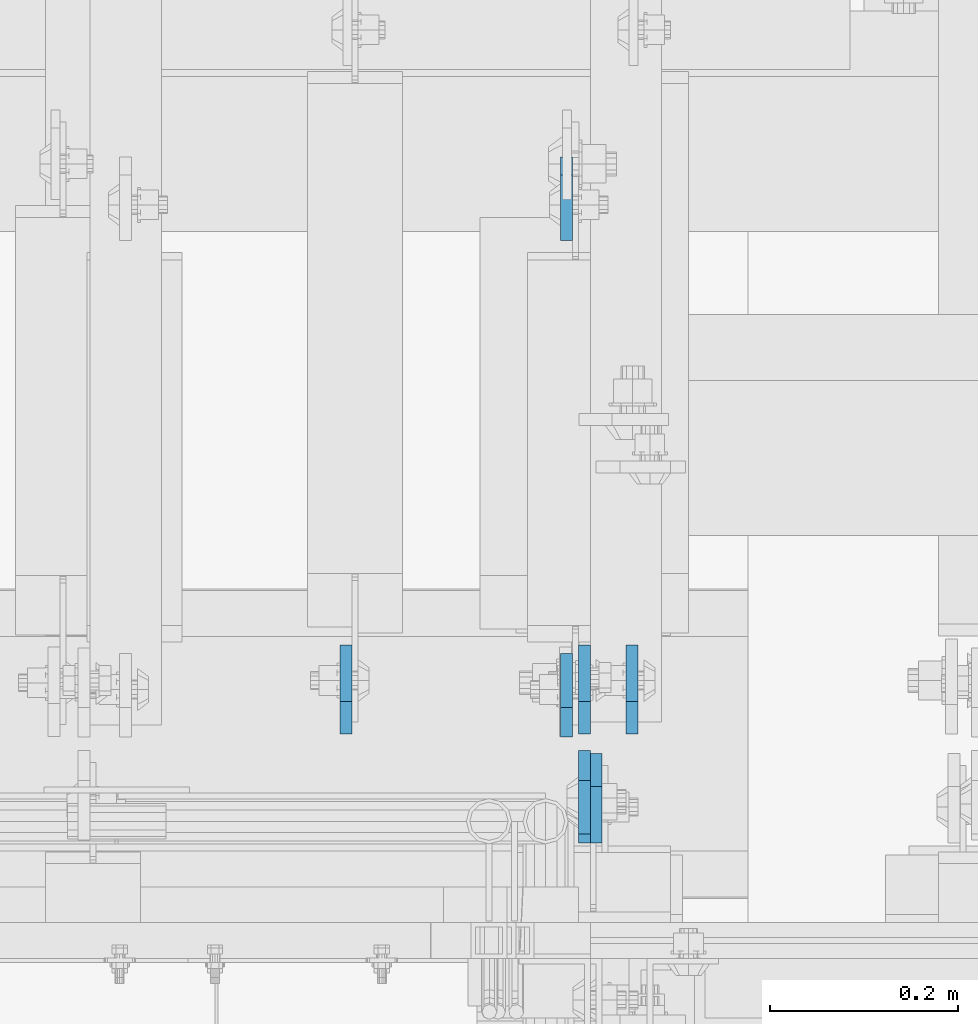
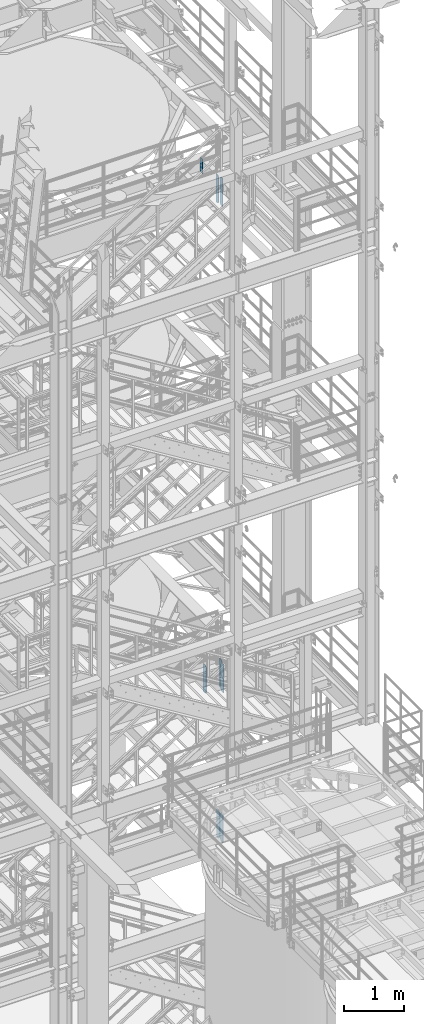
# One storey, part 1502 of 1876: 8 plates, 4 elements without a shape of their own.
"""IFC2X3 building model written with IfcOpenShell, lengths in millimetres."""

from ifc_helpers import new_model, si_unit, frame, origin_with_axes, place, context, subcontext, project, spatial, faceted_brep, material, type_object, element, aggregate, save


model = new_model("IFC2X3")

# Units and contexts
model_context = context("Model", 3, precision=1e-05, world=origin_with_axes())
body_context = subcontext(model_context, "Body", "Model", "MODEL_VIEW")
ifc_project = project(units=[si_unit("LENGTHUNIT", "METRE", prefix="MILLI"), si_unit("AREAUNIT", "SQUARE_METRE"), si_unit("VOLUMEUNIT", "CUBIC_METRE"), si_unit("MASSUNIT", "GRAM", prefix="KILO"), si_unit("TIMEUNIT", "SECOND"), si_unit("PLANEANGLEUNIT", "RADIAN"), si_unit("SOLIDANGLEUNIT", "STERADIAN"), si_unit("THERMODYNAMICTEMPERATUREUNIT", "DEGREE_CELSIUS"), si_unit("LUMINOUSINTENSITYUNIT", "LUMEN")], contexts=[model_context])

# Site, building, storey
site_placement = place(None, origin_with_axes())
site = spatial("IfcSite", under=ifc_project, at=site_placement, CompositionType="ELEMENT")
building_placement = place(site_placement, origin_with_axes())
building = spatial("IfcBuilding", under=site, at=building_placement, Name="Undefined", CompositionType="ELEMENT")
storey_placement = place(building_placement, origin_with_axes())
storey = spatial("IfcBuildingStorey", under=building, at=storey_placement, Name="Undefined", CompositionType="ELEMENT", Elevation=0.0)

# Assembly, plate
assembly_1_placement = place(storey_placement, origin_with_axes())
assembly_1 = element("IfcElementAssembly", 1, at=assembly_1_placement, inside=storey, Name="BEAM", AssemblyPlace="NOTDEFINED", PredefinedType="RIGID_FRAME")
ifc_material = material(Name="STEEL/A36")
plate_type_1 = type_object("IfcPlateType", PredefinedType="NOTDEFINED")
plate_1_placement = place(assembly_1_placement, frame((6238.87499990463, -4579.14375, 17386.3), z_axis=(0.0, 0.0, 1.0), x_axis=(0.0, -1.0, 0.0)))
plate_1 = element("IfcPlate", 2, at=plate_1_placement, type_object=plate_type_1, material=ifc_material, Name="PLATE", context=body_context, shape_type="Brep", body=[
    faceted_brep([(0.0, -6.34999999999991, 31.75), (0.0, -6.34999999999991, 539.75), (0.0, 6.34999999999991, 539.75), (0.0, 6.34999999999991, 31.75), (31.75, -6.34999999999991, 571.5), (31.75, 6.34999999999991, 571.5), (88.9000015258789, -6.34999999999991, 571.5), (88.9000015258789, 6.34999999999991, 571.5), (88.9000015258789, -6.34999999999991, 0.0), (88.9000015258789, 6.34999999999991, 0.0), (31.75, -6.34999999999991, 0.0), (31.75, 6.34999999999991, 0.0)], [[[0, 1, 2, 3]], [[1, 4, 5, 2]], [[4, 6, 7, 5]], [[6, 8, 9, 7]], [[8, 10, 11, 9]], [[10, 0, 3, 11]], [[5, 7, 9, 11, 3, 2]], [[10, 8, 6, 4, 1, 0]]]),
])

assembly_2_placement = place(storey_placement, origin_with_axes())
assembly_2 = element("IfcElementAssembly", 3, at=assembly_2_placement, inside=storey, Name="BEAM", AssemblyPlace="NOTDEFINED", PredefinedType="RIGID_FRAME")
plate_2_placement = place(assembly_2_placement, frame((6219.82499988935, -3946.525, 17679.9875), z_axis=(0.0, 0.0, 1.0), x_axis=(0.0, -1.0, 0.0)))
plate_2 = element("IfcPlate", 4, at=plate_2_placement, type_object=plate_type_1, material=ifc_material, Name="PLATE", context=body_context, shape_type="Brep", body=[
    faceted_brep([(0.0, -6.35000000000196, 19.0499992370605), (9.09494701772928e-13, -6.34999999999832, 273.050006866455), (-2.72848410531878e-12, 6.34999999999923, 273.050006866455), (0.0, 6.35000000000105, 19.0499992370605), (19.0499992370578, -6.35000000000696, 292.100006103516), (19.049999237056, 6.3499999999915, 292.100006103516), (88.9000015258789, -6.35000000000036, 292.100006103516), (88.9000015258789, 6.35000000000036, 292.100006103516), (88.9000015258789, -6.34999999999991, 0.0), (88.9000015258789, 6.34999999999991, 0.0), (19.0499992370642, -6.35000000000105, 0.0), (19.0499992370633, 6.35000000000105, 0.0)], [[[0, 1, 2, 3]], [[1, 4, 5, 2]], [[4, 6, 7, 5]], [[6, 8, 9, 7]], [[8, 10, 11, 9]], [[10, 0, 3, 11]], [[5, 7, 9, 11, 3, 2]], [[10, 8, 6, 4, 1, 0]]]),
])
aggregate(assembly_2, [plate_2])

# Plate
plate_3_placement = place(assembly_1_placement, frame((6219.82499990463, -4564.85625, 17386.3), z_axis=(0.0, 0.0, 1.0), x_axis=(0.0, 1.0, 0.0)))
plate_3 = element("IfcPlate", 5, at=plate_3_placement, type_object=plate_type_1, material=ifc_material, Name="PLATE", context=body_context, shape_type="Brep", body=[
    faceted_brep([(0.0, -6.34999999999991, 31.75), (0.0, -6.34999999999991, 539.75), (0.0, 6.34999999999991, 539.75), (0.0, 6.34999999999991, 31.75), (31.75, -6.34999999999991, 571.5), (31.75, 6.34999999999991, 571.5), (88.9000015258789, -6.34999999999991, 571.5), (88.9000015258789, 6.34999999999991, 571.5), (88.9000015258789, -6.34999999999991, 0.0), (88.9000015258789, 6.34999999999991, 0.0), (31.75, -6.34999999999991, 0.0), (31.75, 6.34999999999991, 0.0)], [[[0, 1, 2, 3]], [[1, 4, 5, 2]], [[4, 6, 7, 5]], [[6, 8, 9, 7]], [[8, 10, 11, 9]], [[10, 0, 3, 11]], [[5, 7, 9, 11, 3, 2]], [[10, 8, 6, 4, 1, 0]]]),
])

aggregate(assembly_1, [plate_1, plate_3])

# Assembly, plates
assembly_3_placement = place(storey_placement, origin_with_axes())
assembly_3 = element("IfcElementAssembly", 6, at=assembly_3_placement, inside=storey, Name="BEAM", AssemblyPlace="NOTDEFINED", PredefinedType="RIGID_FRAME")
plate_type_2 = type_object("IfcPlateType", PredefinedType="NOTDEFINED")
plate_4_placement = place(assembly_3_placement, frame((6251.57499990463, -4582.31875, 7543.8), z_axis=(0.0, 0.0, 1.0), x_axis=(0.0, -1.0, 0.0)))
plate_4 = element("IfcPlate", 7, at=plate_4_placement, type_object=plate_type_2, material=ifc_material, Name="PLATE", context=body_context, shape_type="Brep", body=[
    faceted_brep([(0.0, -6.34999999999991, 34.9249992370605), (0.0, -6.35000000000036, 538.162475585938), (0.0, 6.35000000000036, 538.162475585938), (0.0, 6.34999999999991, 34.9249992370605), (34.9249992370605, -6.34999999999991, 573.087524414062), (34.9249992370605, 6.34999999999991, 573.087524414062), (95.25, -6.34999999999991, 573.087524414062), (95.25, 6.34999999999991, 573.087524414062), (95.25, -6.35000000000036, 0.0), (95.25, 6.35000000000036, 0.0), (34.9249992370605, -6.34999999999991, 0.0), (34.9249992370605, 6.34999999999991, 0.0)], [[[0, 1, 2, 3]], [[1, 4, 5, 2]], [[4, 6, 7, 5]], [[6, 8, 9, 7]], [[8, 10, 11, 9]], [[10, 0, 3, 11]], [[5, 7, 9, 11, 3, 2]], [[10, 8, 6, 4, 1, 0]]]),
])
plate_5_placement = place(assembly_3_placement, frame((5984.87499990463, -4561.68125, 7543.8), z_axis=(0.0, 0.0, 1.0), x_axis=(0.0, 1.0, 0.0)))
plate_5 = element("IfcPlate", 8, at=plate_5_placement, type_object=plate_type_2, material=ifc_material, Name="PLATE", context=body_context, shape_type="Brep", body=[
    faceted_brep([(0.0, -6.34999999999991, 34.9249992370605), (0.0, -6.35000000000036, 538.162475585938), (0.0, 6.35000000000036, 538.162475585938), (0.0, 6.34999999999991, 34.9249992370605), (34.9249992370605, -6.34999999999991, 573.087524414062), (34.9249992370605, 6.34999999999991, 573.087524414062), (95.25, -6.34999999999991, 573.087524414062), (95.25, 6.34999999999991, 573.087524414062), (95.25, -6.35000000000036, 0.0), (95.25, 6.35000000000036, 0.0), (34.9249992370605, -6.34999999999991, 0.0), (34.9249992370605, 6.34999999999991, 0.0)], [[[0, 1, 2, 3]], [[1, 4, 5, 2]], [[4, 6, 7, 5]], [[6, 8, 9, 7]], [[8, 10, 11, 9]], [[10, 0, 3, 11]], [[5, 7, 9, 11, 3, 2]], [[10, 8, 6, 4, 1, 0]]]),
])
plate_6_placement = place(assembly_3_placement, frame((6289.67499990463, -4561.68125, 7543.8), z_axis=(0.0, 0.0, 1.0), x_axis=(0.0, 1.0, 0.0)))
plate_6 = element("IfcPlate", 9, at=plate_6_placement, type_object=plate_type_2, material=ifc_material, Name="PLATE", context=body_context, shape_type="Brep", body=[
    faceted_brep([(0.0, -6.34999999999991, 34.9249992370605), (0.0, -6.35000000000036, 538.162475585938), (0.0, 6.35000000000036, 538.162475585938), (0.0, 6.34999999999991, 34.9249992370605), (34.9249992370605, -6.34999999999991, 573.087524414062), (34.9249992370605, 6.34999999999991, 573.087524414062), (95.25, -6.34999999999991, 573.087524414062), (95.25, 6.34999999999991, 573.087524414062), (95.25, -6.35000000000036, 0.0), (95.25, 6.35000000000036, 0.0), (34.9249992370605, -6.34999999999991, 0.0), (34.9249992370605, 6.34999999999991, 0.0)], [[[0, 1, 2, 3]], [[1, 4, 5, 2]], [[4, 6, 7, 5]], [[6, 8, 9, 7]], [[8, 10, 11, 9]], [[10, 0, 3, 11]], [[5, 7, 9, 11, 3, 2]], [[10, 8, 6, 4, 1, 0]]]),
])
aggregate(assembly_3, [plate_4, plate_5, plate_6])

assembly_4_placement = place(storey_placement, origin_with_axes())
assembly_4 = element("IfcElementAssembly", 10, at=assembly_4_placement, inside=storey, Name="BEAM", AssemblyPlace="NOTDEFINED", PredefinedType="RIGID_FRAME")
plate_7_placement = place(assembly_4_placement, frame((6238.875, -4582.31875, 4521.2), z_axis=(0.0, 0.0, 1.0), x_axis=(0.0, -1.0, 0.0)))
plate_7 = element("IfcPlate", 11, at=plate_7_placement, type_object=plate_type_2, material=ifc_material, Name="PLATE", context=body_context, shape_type="Brep", body=[
    faceted_brep([(0.0, -6.34999999999991, 34.9249992370605), (0.0, -6.35000000000036, 538.162475585938), (0.0, 6.35000000000036, 538.162475585938), (0.0, 6.34999999999991, 34.9249992370605), (34.9249992370605, -6.34999999999991, 573.087524414062), (34.9249992370605, 6.34999999999991, 573.087524414062), (95.25, -6.34999999999991, 573.087524414062), (95.25, 6.34999999999991, 573.087524414062), (95.25, -6.35000000000036, 0.0), (95.25, 6.35000000000036, 0.0), (34.9249992370605, -6.34999999999991, 0.0), (34.9249992370605, 6.34999999999991, 0.0)], [[[0, 1, 2, 3]], [[1, 4, 5, 2]], [[4, 6, 7, 5]], [[6, 8, 9, 7]], [[8, 10, 11, 9]], [[10, 0, 3, 11]], [[5, 7, 9, 11, 3, 2]], [[10, 8, 6, 4, 1, 0]]]),
])
plate_8_placement = place(assembly_4_placement, frame((6238.875, -4561.68125, 4521.2), z_axis=(0.0, 0.0, 1.0), x_axis=(0.0, 1.0, 0.0)))
plate_8 = element("IfcPlate", 12, at=plate_8_placement, type_object=plate_type_2, material=ifc_material, Name="PLATE", context=body_context, shape_type="Brep", body=[
    faceted_brep([(0.0, -6.34999999999991, 34.9249992370605), (0.0, -6.35000000000036, 538.162475585938), (0.0, 6.35000000000036, 538.162475585938), (0.0, 6.34999999999991, 34.9249992370605), (34.9249992370605, -6.34999999999991, 573.087524414062), (34.9249992370605, 6.34999999999991, 573.087524414062), (95.25, -6.34999999999991, 573.087524414062), (95.25, 6.34999999999991, 573.087524414062), (95.25, -6.35000000000036, 0.0), (95.25, 6.35000000000036, 0.0), (34.9249992370605, -6.34999999999991, 0.0), (34.9249992370605, 6.34999999999991, 0.0)], [[[0, 1, 2, 3]], [[1, 4, 5, 2]], [[4, 6, 7, 5]], [[6, 8, 9, 7]], [[8, 10, 11, 9]], [[10, 0, 3, 11]], [[5, 7, 9, 11, 3, 2]], [[10, 8, 6, 4, 1, 0]]]),
])
aggregate(assembly_4, [plate_7, plate_8])

save(model, "model.ifc")
